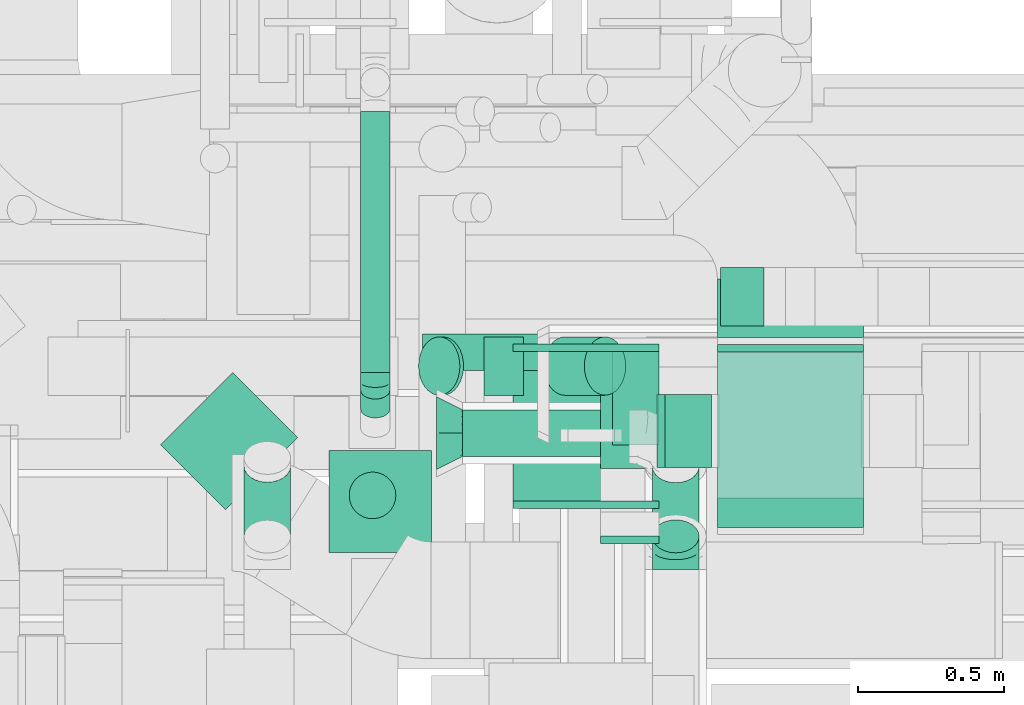
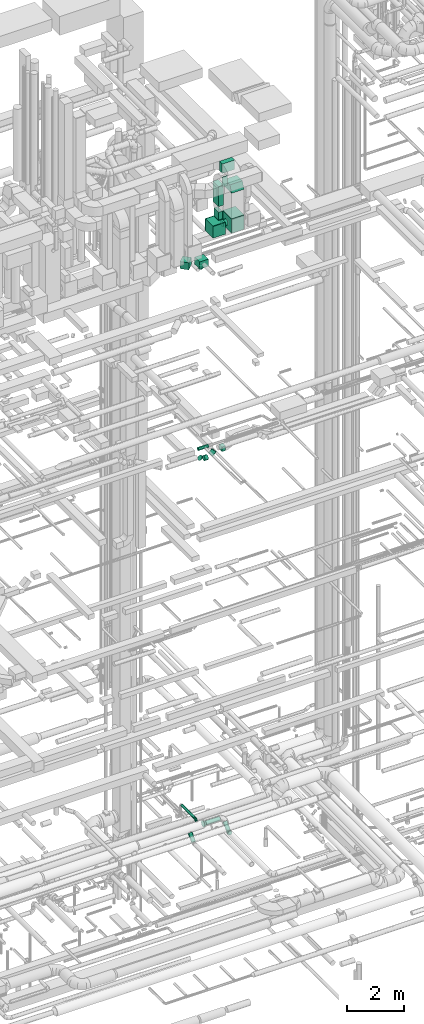
# One storey, part 232 of 337: 19 flow segments, 11 flow fittings.
"""IFC2X3 building model written with IfcOpenShell, lengths in millimetres."""

from ifc_helpers import new_model, entity, si_unit, converted_unit, derived_unit, direction, frame, origin, origin_2d_with_axis, place, context, subcontext, project, spatial, polyline, rectangle, circle, outline, extrude, faceted_brep, source, transform, mapped, material, type_object, type_shapes, element, save


model = new_model("IFC2X3")

# Units and contexts
model_context = context("Model", 3, precision=0.01, world=origin(), true_north=direction((6.12303176911189e-17, 1.0)))
body_context = subcontext(model_context, "Body", "Model", "MODEL_VIEW")
ifc_project = project(units=[si_unit("LENGTHUNIT", "METRE", prefix="MILLI"), si_unit("AREAUNIT", "SQUARE_METRE"), si_unit("VOLUMEUNIT", "CUBIC_METRE"), converted_unit("PLANEANGLEUNIT", "DEGREE", entity("IfcRatioMeasure", 0.0174532925199433), si_unit("PLANEANGLEUNIT", "RADIAN"), dimensions=[0, 0, 0, 0, 0, 0, 0]), si_unit("MASSUNIT", "GRAM", prefix="KILO"), derived_unit("MASSDENSITYUNIT", [(si_unit("MASSUNIT", "GRAM", prefix="KILO"), 1), (si_unit("LENGTHUNIT", "METRE"), -3)]), derived_unit("MOMENTOFINERTIAUNIT", [(si_unit("LENGTHUNIT", "METRE"), 4)]), si_unit("TIMEUNIT", "SECOND"), si_unit("FREQUENCYUNIT", "HERTZ"), si_unit("THERMODYNAMICTEMPERATUREUNIT", "DEGREE_CELSIUS"), derived_unit("THERMALTRANSMITTANCEUNIT", [(si_unit("MASSUNIT", "GRAM", prefix="KILO"), 1), (si_unit("THERMODYNAMICTEMPERATUREUNIT", "KELVIN"), -1), (si_unit("TIMEUNIT", "SECOND"), -3)]), derived_unit("VOLUMETRICFLOWRATEUNIT", [(si_unit("LENGTHUNIT", "METRE"), 3), (si_unit("TIMEUNIT", "SECOND"), -1)]), derived_unit("MASSFLOWRATEUNIT", [(si_unit("MASSUNIT", "GRAM", prefix="KILO"), 1), (si_unit("TIMEUNIT", "SECOND"), -1)]), derived_unit("ROTATIONALFREQUENCYUNIT", [(si_unit("TIMEUNIT", "SECOND"), -1)]), si_unit("ELECTRICCURRENTUNIT", "AMPERE"), si_unit("ELECTRICVOLTAGEUNIT", "VOLT"), si_unit("POWERUNIT", "WATT"), si_unit("FORCEUNIT", "NEWTON", prefix="KILO"), si_unit("ILLUMINANCEUNIT", "LUX"), si_unit("LUMINOUSFLUXUNIT", "LUMEN"), si_unit("LUMINOUSINTENSITYUNIT", "CANDELA"), derived_unit("USERDEFINED", [(si_unit("MASSUNIT", "GRAM", prefix="KILO"), -1), (si_unit("LENGTHUNIT", "METRE"), -2), (si_unit("TIMEUNIT", "SECOND"), 3), (si_unit("LUMINOUSFLUXUNIT", "LUMEN"), 1)]), derived_unit("LINEARVELOCITYUNIT", [(si_unit("LENGTHUNIT", "METRE"), 1), (si_unit("TIMEUNIT", "SECOND"), -1)]), si_unit("PRESSUREUNIT", "PASCAL"), derived_unit("USERDEFINED", [(si_unit("LENGTHUNIT", "METRE"), -2), (si_unit("MASSUNIT", "GRAM", prefix="KILO"), 1), (si_unit("TIMEUNIT", "SECOND"), -2)]), derived_unit("LINEARFORCEUNIT", [(si_unit("MASSUNIT", "GRAM", prefix="KILO"), 1), (si_unit("LENGTHUNIT", "METRE"), 1), (si_unit("TIMEUNIT", "SECOND"), -2), (si_unit("LENGTHUNIT", "METRE"), -1)]), derived_unit("PLANARFORCEUNIT", [(si_unit("MASSUNIT", "GRAM", prefix="KILO"), 1), (si_unit("LENGTHUNIT", "METRE"), 1), (si_unit("TIMEUNIT", "SECOND"), -2), (si_unit("LENGTHUNIT", "METRE"), -2)])], contexts=[model_context])

# Site, building, storey
site_placement = place(None, origin())
site = spatial("IfcSite", under=ifc_project, at=site_placement, CompositionType="ELEMENT")
building_placement = place(site_placement, origin())
building = spatial("IfcBuilding", under=site, at=building_placement, CompositionType="ELEMENT")
storey_placement = place(building_placement, origin())
storey = spatial("IfcBuildingStorey", under=building, at=storey_placement, CompositionType="ELEMENT", Elevation=0.0)

# Flow segments
duct_segment_type_1 = type_object("IfcDuctSegmentType", PredefinedType="NOTDEFINED")
flow_segment_1_placement = place(storey_placement, frame((61880.06, 9475.53, 18750.0)))
element("IfcFlowSegment", 1, at=flow_segment_1_placement, inside=storey, type_object=duct_segment_type_1, context=body_context, shape_type="SweptSolid", body=[
    extrude(rectangle(XDim=148.732589066645, YDim=200.0, at=origin_2d_with_axis()), frame((74.37, 100.0, 0.0)), (0.0, 0.0, 1.0), 199.999999999998),
])
flow_segment_2_placement = place(storey_placement, frame((60539.45, 8700.02, 27450.0)))
element("IfcFlowSegment", 2, at=flow_segment_2_placement, inside=storey, type_object=duct_segment_type_1, context=body_context, shape_type="SweptSolid", body=[
    extrude(rectangle(XDim=352.280592228734, YDim=349.999999999999, at=origin_2d_with_axis()), frame((176.14, 175.0, 0.0), z_axis=(0.0, 0.0, 1.0), x_axis=(-1.0, 0.0, 0.0)), (0.0, 0.0, 1.0), 300.000000000001),
])
flow_segment_3_placement = place(storey_placement, frame((61870.03, 9436.6, 30600.0)))
element("IfcFlowSegment", 3, at=flow_segment_3_placement, inside=storey, type_object=duct_segment_type_1, context=body_context, shape_type="SweptSolid", body=[
    extrude(rectangle(XDim=200.89666130683, YDim=499.999999999999, at=origin_2d_with_axis()), frame((250.0, 100.45, 0.0), z_axis=(0.0, 0.0, 1.0), x_axis=(0.0, 1.0, 0.0)), (0.0, 0.0, 1.0), 400.000000000004),
])
flow_segment_4_placement = place(storey_placement, frame((61870.03, 8786.6, 28450.0)))
element("IfcFlowSegment", 4, at=flow_segment_4_placement, inside=storey, type_object=duct_segment_type_1, context=body_context, shape_type="SweptSolid", body=[
    extrude(rectangle(XDim=600.0, YDim=499.999999999999, at=origin_2d_with_axis()), frame((250.0, 300.0, 0.0), z_axis=(0.0, 0.0, 1.0), x_axis=(0.0, 1.0, 0.0)), (0.0, 0.0, 1.0), 600.000000000002),
])
flow_segment_5_placement = place(storey_placement, frame((61170.03, 8876.6, 28450.0)))
element("IfcFlowSegment", 5, at=flow_segment_5_placement, inside=storey, type_object=duct_segment_type_1, context=body_context, shape_type="SweptSolid", body=[
    extrude(rectangle(XDim=512.000000000001, YDim=499.999999999999, at=origin_2d_with_axis()), frame((250.0, 256.0, 0.0), z_axis=(0.0, 0.0, 1.0), x_axis=(0.0, 1.0, 0.0)), (0.0, 0.0, 1.0), 499.999999999999),
])
flow_segment_6_placement = place(storey_placement, frame((61510.03, 9068.6, 28970.0)))
element("IfcFlowSegment", 6, at=flow_segment_6_placement, inside=storey, type_object=duct_segment_type_1, context=body_context, shape_type="SweptSolid", body=[
    extrude(rectangle(XDim=159.999999999998, YDim=320.0, at=origin_2d_with_axis()), frame((80.0, 160.0, 0.0), z_axis=(0.0, 0.0, 1.0), x_axis=(-1.0, 0.0, 0.0)), (0.0, 0.0, 1.0), 330.000000000055),
])
flow_segment_7_placement = place(storey_placement, frame((61470.03, 8988.6, 29600.0)))
element("IfcFlowSegment", 7, at=flow_segment_7_placement, inside=storey, type_object=duct_segment_type_1, context=body_context, shape_type="SweptSolid", body=[
    extrude(rectangle(XDim=399.999999999999, YDim=199.999999999998, at=origin_2d_with_axis()), frame((100.0, 200.0, 0.0), z_axis=(0.0, 0.0, 1.0), x_axis=(0.0, -1.0, 0.0)), (0.0, 0.0, 1.0), 850.000025000003),
])
flow_segment_8_placement = place(storey_placement, frame((59963.18, 8846.47, 27450.0)))
element("IfcFlowSegment", 8, at=flow_segment_8_placement, inside=storey, type_object=duct_segment_type_1, context=body_context, shape_type="SweptSolid", body=[
    extrude(rectangle(XDim=314.97280707382, YDim=349.999999999997, at=origin_2d_with_axis()), frame((235.1, 235.1, 0.0), z_axis=(0.0, 0.0, 1.0), x_axis=(-0.707106781186537, 0.707106781186558, 0.0)), (0.0, 0.0, 1.0), 300.000000000001),
])
duct_segment_type_2 = type_object("IfcDuctSegmentType", PredefinedType="NOTDEFINED")
flow_segment_9_placement = place(storey_placement, frame((60997.4, 9027.05, 3418.43)))
element("IfcFlowSegment", 9, at=flow_segment_9_placement, inside=storey, type_object=duct_segment_type_2, context=body_context, shape_type="SweptSolid", body=[
    extrude(circle(Radius=80.0, at=origin_2d_with_axis()), frame((0.0, 81.6, 81.6), z_axis=(1.0, 0.0, 0.0), x_axis=(0.0, 1.0, 0.0)), (0.0, 0.0, 1.0), 570.000194736215),
])
flow_segment_10_placement = place(storey_placement, frame((60859.84, 9321.02, 19210.9)))
element("IfcFlowSegment", 10, at=flow_segment_10_placement, inside=storey, type_object=duct_segment_type_2, context=body_context, shape_type="SweptSolid", body=[
    extrude(circle(Radius=62.5, at=origin_2d_with_axis()), frame((0.0, 64.1, 64.1), z_axis=(1.0, 0.0, 0.0), x_axis=(0.0, 1.0, 0.0)), (0.0, 0.0, 1.0), 410.000000000115),
])
flow_segment_11_placement = place(storey_placement, frame((61071.51, 9236.98, 18743.4)))
element("IfcFlowSegment", 11, at=flow_segment_11_placement, inside=storey, type_object=duct_segment_type_2, context=body_context, shape_type="SweptSolid", body=[
    extrude(circle(Radius=100.0, at=origin_2d_with_axis()), frame((0.0, 101.6, 101.6), z_axis=(1.0, 0.0, 0.0), x_axis=(0.0, -1.0, 0.0)), (0.0, 0.0, 1.0), 134.314575050791),
])
flow_segment_12_placement = place(storey_placement, frame((60845.12, 9236.98, 18831.27)))
element("IfcFlowSegment", 12, at=flow_segment_12_placement, inside=storey, type_object=duct_segment_type_2, context=body_context, shape_type="SweptSolid", body=[
    extrude(circle(Radius=100.0, at=origin_2d_with_axis()), frame((84.96, 101.6, 72.31), z_axis=(-0.707106781186417, 0.0, 0.707106781186678), x_axis=(0.0, 1.0, 0.0)), (0.0, 0.0, 1.0), 17.9011977120001),
])
flow_segment_13_placement = place(storey_placement, frame((61274.94, 9236.98, 18831.27)))
element("IfcFlowSegment", 13, at=flow_segment_13_placement, inside=storey, type_object=duct_segment_type_2, context=body_context, shape_type="SweptSolid", body=[
    extrude(circle(Radius=100.0, at=origin_2d_with_axis()), frame((72.31, 101.6, 72.31), z_axis=(0.707106781186552, 0.0, 0.707106781186543), x_axis=(0.0, -1.0, 0.0)), (0.0, 0.0, 1.0), 194.93903345586),
])
flow_segment_14_placement = place(storey_placement, frame((61690.03, 8988.89, 28613.4)))
element("IfcFlowSegment", 14, at=flow_segment_14_placement, inside=storey, type_object=duct_segment_type_2, context=body_context, shape_type="SweptSolid", body=[
    extrude(circle(Radius=125.0, at=origin_2d_with_axis()), frame((0.0, 126.6, 126.6), z_axis=(1.0, 0.0, 0.0), x_axis=(0.0, -1.0, 0.0)), (0.0, 0.0, 1.0), 159.999999999929),
])
flow_segment_15_placement = place(storey_placement, frame((60247.19, 8696.29, 3088.7)))
element("IfcFlowSegment", 15, at=flow_segment_15_placement, inside=storey, type_object=duct_segment_type_2, context=body_context, shape_type="SweptSolid", body=[
    extrude(circle(Radius=80.0, at=origin_2d_with_axis()), frame((81.6, 58.17, 58.16), z_axis=(0.0, 0.707065975990968, 0.707147584027507), x_axis=(-1.0, 0.0, 0.0)), (0.0, 0.0, 1.0), 343.340340356548),
])
flow_segment_16_placement = place(storey_placement, frame((60646.81, 9315.73, 3648.4)))
element("IfcFlowSegment", 16, at=flow_segment_16_placement, inside=storey, type_object=duct_segment_type_2, context=body_context, shape_type="SweptSolid", body=[
    extrude(circle(Radius=50.0, at=origin_2d_with_axis()), frame((51.6, 0.0, 51.6), z_axis=(0.0, 1.0, 0.0), x_axis=(-1.0, 0.0, 0.0)), (0.0, 0.0, 1.0), 894.354512811127),
])
flow_segment_17_placement = place(storey_placement, frame((60607.25, 8814.03, 27320.0)))
element("IfcFlowSegment", 17, at=flow_segment_17_placement, inside=storey, type_object=duct_segment_type_2, context=body_context, shape_type="SweptSolid", body=[
    extrude(circle(Radius=80.0, at=origin_2d_with_axis()), frame((81.6, 81.6, 0.0)), (0.0, 0.0, 1.0), 109.999999999901),
])
flow_segment_18_placement = place(storey_placement, frame((61645.81, 8697.35, 3088.7)))
element("IfcFlowSegment", 18, at=flow_segment_18_placement, inside=storey, type_object=duct_segment_type_2, context=body_context, shape_type="SweptSolid", body=[
    extrude(circle(Radius=80.0, at=origin_2d_with_axis()), frame((81.6, 58.17, 58.16), z_axis=(0.0, 0.707057032292688, 0.707156526580542), x_axis=(1.0, 0.0, 0.0)), (0.0, 0.0, 1.0), 339.426965556956),
])
flow_segment_19_placement = place(storey_placement, frame((60646.81, 9159.44, 3589.8)))
element("IfcFlowSegment", 19, at=flow_segment_19_placement, inside=storey, type_object=duct_segment_type_2, context=body_context, shape_type="SweptSolid", body=[
    extrude(circle(Radius=50.0, at=origin_2d_with_axis()), frame((51.6, 31.67, 41.54), z_axis=(0.0, 0.798836695069903, 0.601547948720461), x_axis=(1.0, 0.0, 0.0)), (0.0, 0.0, 1.0), 80.6610962379535),
])

# Flow fittings
ifc_material = material()
duct_fitting_type_1 = type_object("IfcDuctFittingType", PredefinedType="NOTDEFINED", material=ifc_material)
shared_shape_1 = source(origin(), body_context, "Body", "SweptSolid", [
    extrude(rectangle(XDim=200.0, YDim=26.096, at=origin_2d_with_axis()), frame((6.95, 0.0, -200.0), z_axis=(0.0, 0.0, 1.0), x_axis=(0.0, -1.0, 0.0)), (0.0, 0.0, 1.0), 400.0),
])
type_shapes(duct_fitting_type_1, [shared_shape_1])
flow_fitting_1_placement = place(storey_placement, frame((61570.03, 8736.6, 30800.0), z_axis=(0.0, 0.0, -1.0), x_axis=(0.0, 1.0, 0.0)))
element("IfcFlowFitting", 20, at=flow_fitting_1_placement, inside=storey, type_object=duct_fitting_type_1, material=ifc_material, context=body_context, shape_type="MappedRepresentation", body=[
    mapped(shared_shape_1, transform((0.0, 0.0, 0.0), scale=1.0)),
])
duct_fitting_type_2 = type_object("IfcDuctFittingType", PredefinedType="NOTDEFINED", material=ifc_material)
shared_shape_2 = source(origin(), body_context, "Body", "SweptSolid", [
    extrude(rectangle(XDim=24.9999999999999, YDim=500.0, at=origin_2d_with_axis()), frame((12.5, 0.0, -300.0)), (0.0, 0.0, 1.0), 600.0),
])
type_shapes(duct_fitting_type_2, [shared_shape_2])
flow_fitting_2_placement = place(storey_placement, frame((62120.03, 9386.6, 28750.0), z_axis=(0.0, 0.0, 1.0), x_axis=(0.0, 1.0, 0.0)))
element("IfcFlowFitting", 21, at=flow_fitting_2_placement, inside=storey, type_object=duct_fitting_type_2, material=ifc_material, context=body_context, shape_type="MappedRepresentation", body=[
    mapped(shared_shape_2, transform((0.0, 0.0, 0.0), scale=1.0)),
])
duct_fitting_type_3 = type_object("IfcDuctFittingType", PredefinedType="NOTDEFINED", material=ifc_material)
shared_shape_3 = source(origin(), body_context, "Body", "SweptSolid", [
    extrude(outline(polyline([(-237.17, -237.17), (79.06, -237.17), (205.55, 142.3), (-47.43, 332.04), (-237.17, -237.17)])), frame((150.0, -250.0, 0.0), z_axis=(0.0, 1.0, 0.0), x_axis=(0.948683298050486, 0.0, -0.316227766016921)), (0.0, 0.0, 1.0), 500.0),
])
type_shapes(duct_fitting_type_3, [shared_shape_3])
flow_fitting_3_placement = place(storey_placement, frame((62120.03, 9086.6, 30150.0), z_axis=(0.0, -1.0, 0.0), x_axis=(0.0, 0.0, 1.0)))
element("IfcFlowFitting", 22, at=flow_fitting_3_placement, inside=storey, type_object=duct_fitting_type_3, material=ifc_material, context=body_context, shape_type="MappedRepresentation", body=[
    mapped(shared_shape_3, transform((0.0, 0.0, 0.0), scale=1.0)),
])
duct_fitting_type_4 = type_object("IfcDuctFittingType", PredefinedType="NOTDEFINED", material=ifc_material)
shared_shape_4 = source(origin(), body_context, "Body", "SweptSolid", [
    extrude(rectangle(XDim=500.0, YDim=26.096, at=origin_2d_with_axis()), frame((6.95, 0.0, -300.0), z_axis=(0.0, 0.0, 1.0), x_axis=(0.0, -1.0, 0.0)), (0.0, 0.0, 1.0), 600.0),
])
type_shapes(duct_fitting_type_4, [shared_shape_4])
flow_fitting_4_placement = place(storey_placement, frame((62120.03, 9086.6, 29050.0), z_axis=(0.0, -1.0, 0.0), x_axis=(0.0, 0.0, 1.0)))
element("IfcFlowFitting", 23, at=flow_fitting_4_placement, inside=storey, type_object=duct_fitting_type_4, material=ifc_material, context=body_context, shape_type="MappedRepresentation", body=[
    mapped(shared_shape_4, transform((0.0, 0.0, 0.0), scale=1.0)),
])
duct_fitting_type_5 = type_object("IfcDuctFittingType", PredefinedType="NOTDEFINED", material=ifc_material)
shared_shape_5 = source(origin(), body_context, "Body", "SweptSolid", [
    extrude(rectangle(XDim=160.0, YDim=26.096, at=origin_2d_with_axis()), frame((6.95, 0.0, -160.0), z_axis=(0.0, 0.0, 1.0), x_axis=(0.0, -1.0, 0.0)), (0.0, 0.0, 1.0), 320.0),
])
type_shapes(duct_fitting_type_5, [shared_shape_5])
flow_fitting_5_placement = place(storey_placement, frame((61590.03, 9228.6, 28950.0), z_axis=(0.0, -1.0, 0.0), x_axis=(0.0, 0.0, 1.0)))
element("IfcFlowFitting", 24, at=flow_fitting_5_placement, inside=storey, type_object=duct_fitting_type_5, material=ifc_material, context=body_context, shape_type="MappedRepresentation", body=[
    mapped(shared_shape_5, transform((0.0, 0.0, 0.0), scale=1.0)),
])
duct_fitting_type_6 = type_object("IfcDuctFittingType", PredefinedType="NOTDEFINED", material=ifc_material)
shared_shape_6 = source(origin(), body_context, "Body", "SweptSolid", [
    extrude(rectangle(XDim=24.9999999999999, YDim=500.0, at=origin_2d_with_axis()), frame((12.5, 0.0, -250.0)), (0.0, 0.0, 1.0), 500.0),
])
type_shapes(duct_fitting_type_6, [shared_shape_6])
for number, where, z_axis, x_axis in (
    (25, (61420.03, 8876.6, 28700.0), (0.0, 0.0, 1.0), (0.0, -1.0, 0.0)),
    (26, (61420.03, 9388.6, 28700.0), (0.0, 0.0, 1.0), (0.0, 1.0, 0.0)),
):
    element("IfcFlowFitting", number, at=place(storey_placement, frame(where, z_axis=z_axis, x_axis=x_axis)), inside=storey, type_object=duct_fitting_type_6, material=ifc_material, context=body_context, shape_type="MappedRepresentation", body=[
        mapped(shared_shape_6, transform((0.0, 0.0, 0.0), scale=1.0)),
    ])
duct_fitting_type_7 = type_object("IfcDuctFittingType", PredefinedType="NOTDEFINED", material=ifc_material)
shared_shape_7 = source(origin(), body_context, "Body", "Brep", [
    faceted_brep([(20.0, 32.35, -120.74), (20.0, 62.5, -108.25), (20.0, 88.39, -88.39), (20.0, 108.25, -62.5), (20.0, 120.74, -32.35), (20.0, 125.0, 0.0), (20.0, 120.74, 32.35), (20.0, 108.25, 62.5), (20.0, 88.39, 88.39), (20.0, 62.5, 108.25), (20.0, 32.35, 120.74), (20.0, 0.0, 125.0), (20.0, -32.35, 120.74), (20.0, -62.5, 108.25), (20.0, -88.39, 88.39), (20.0, -108.25, 62.5), (20.0, -120.74, 32.35), (20.0, -125.0, 0.0), (20.0, -120.74, -32.35), (20.0, -108.25, -62.5), (20.0, -88.39, -88.39), (20.0, -62.5, -108.25), (20.0, -32.35, -120.74), (20.0, 0.0, -125.0), (0.0, 0.0, 125.0), (0.0, 32.35, 120.74), (-6.1, 32.35, 120.74), (-6.1, 0.0, 125.0), (0.0, 62.5, 108.25), (-6.1, 62.5, 108.25), (0.0, 88.39, 88.39), (-6.1, 88.39, 88.39), (0.0, 108.25, 62.5), (0.0, 120.74, 32.35), (-6.1, 120.74, 32.35), (-6.1, 108.25, 62.5), (0.0, 125.0, 0.0), (-6.1, 125.0, 0.0), (0.0, 120.74, -32.35), (-6.1, 120.74, -32.35), (0.0, 108.25, -62.5), (-6.1, 108.25, -62.5), (0.0, 88.39, -88.39), (-6.1, 88.39, -88.39), (0.0, 62.5, -108.25), (0.0, 32.35, -120.74), (-6.1, 32.35, -120.74), (-6.1, 62.5, -108.25), (0.0, 0.0, -125.0), (-6.1, 0.0, -125.0), (0.0, -32.35, -120.74), (-6.1, -32.35, -120.74), (0.0, -62.5, -108.25), (-6.1, -62.5, -108.25), (0.0, -88.39, -88.39), (-6.1, -88.39, -88.39), (0.0, -108.25, -62.5), (0.0, -120.74, -32.35), (-6.1, -120.74, -32.35), (-6.1, -108.25, -62.5), (0.0, -125.0, 0.0), (-6.1, -125.0, 0.0), (0.0, -120.74, 32.35), (-6.1, -120.74, 32.35), (0.0, -108.25, 62.5), (-6.1, -108.25, 62.5), (0.0, -88.39, 88.39), (-6.1, -88.39, 88.39), (0.0, -62.5, 108.25), (0.0, -32.35, 120.74), (-6.1, -32.35, 120.74), (-6.1, -62.5, 108.25)], [[[0, 1, 2, 3, 4, 5, 6, 7, 8, 9, 10, 11, 12, 13, 14, 15, 16, 17, 18, 19, 20, 21, 22, 23]], [[24, 11, 10, 25, 26, 27]], [[25, 10, 9, 28, 29, 26]], [[28, 9, 8, 30, 31, 29]], [[32, 7, 6, 33, 34, 35]], [[33, 6, 5, 36, 37, 34]], [[30, 8, 7, 32, 35, 31]], [[36, 5, 4, 38, 39, 37]], [[38, 4, 3, 40, 41, 39]], [[40, 3, 2, 42, 43, 41]], [[44, 1, 0, 45, 46, 47]], [[45, 0, 23, 48, 49, 46]], [[42, 2, 1, 44, 47, 43]], [[48, 23, 22, 50, 51, 49]], [[50, 22, 21, 52, 53, 51]], [[52, 21, 20, 54, 55, 53]], [[56, 19, 18, 57, 58, 59]], [[57, 18, 17, 60, 61, 58]], [[54, 20, 19, 56, 59, 55]], [[60, 17, 16, 62, 63, 61]], [[62, 16, 15, 64, 65, 63]], [[64, 15, 14, 66, 67, 65]], [[68, 13, 12, 69, 70, 71]], [[69, 12, 11, 24, 27, 70]], [[66, 14, 13, 68, 71, 67]], [[49, 51, 53, 55, 59, 58, 61, 63, 65, 67, 71, 70, 27, 26, 29, 31, 35, 34, 37, 39, 41, 43, 47, 46]]]),
])
type_shapes(duct_fitting_type_7, [shared_shape_7])
flow_fitting_6_placement = place(storey_placement, frame((61670.03, 9115.48, 28740.0), z_axis=(0.0, 0.0, -1.0), x_axis=(1.0, 0.0, 0.0)))
element("IfcFlowFitting", 27, at=flow_fitting_6_placement, inside=storey, type_object=duct_fitting_type_7, material=ifc_material, context=body_context, shape_type="MappedRepresentation", body=[
    mapped(shared_shape_7, transform((0.0, 0.0, 0.0), scale=1.0)),
])
duct_fitting_type_8 = type_object("IfcDuctFittingType", PredefinedType="NOTDEFINED", material=ifc_material)
shared_shape_8 = source(origin(), body_context, "Body", "Brep", [
    faceted_brep([(-66.27, 0.0, -80.0), (-66.27, -20.71, -77.27), (-66.27, -40.0, -69.28), (-66.27, -56.57, -56.57), (-66.27, -69.28, -40.0), (-66.27, -77.27, -20.71), (-66.27, -80.0, 0.0), (-66.27, -77.27, 20.71), (-66.27, -69.28, 40.0), (-66.27, -56.57, 56.57), (-66.27, -40.0, 69.28), (-66.27, -20.71, 77.27), (-66.27, 0.0, 80.0), (-66.27, 20.71, 77.27), (-66.27, 40.0, 69.28), (-66.27, 56.57, 56.57), (-66.27, 69.28, 40.0), (-66.27, 77.27, 20.71), (-66.27, 80.0, 0.0), (-66.27, 77.27, -20.71), (-66.27, 69.28, -40.0), (-66.27, 56.57, -56.57), (-66.27, 40.0, -69.28), (-66.27, 20.71, -77.27), (-8.58, 20.71, 77.27), (-16.57, 40.0, 69.28), (0.0, 0.0, 80.0), (-23.43, 56.57, 56.57), (-28.7, 69.28, 40.0), (-32.01, 77.27, 20.71), (-33.14, 80.0, 0.0), (-32.01, 77.27, -20.71), (-28.7, 69.28, -40.0), (-23.43, 56.57, -56.57), (-8.58, 20.71, -77.27), (0.0, 0.0, -80.0), (-16.57, 40.0, -69.28), (8.58, -20.71, -77.27), (16.57, -40.0, -69.28), (23.43, -56.57, -56.57), (28.7, -69.28, -40.0), (32.01, -77.27, -20.71), (33.14, -80.0, 0.0), (32.01, -77.27, 20.71), (28.7, -69.28, 40.0), (23.43, -56.57, 56.57), (16.57, -40.0, 69.28), (8.58, -20.71, 77.27), (46.86, 46.86, 80.0), (32.22, 61.5, 77.27), (18.58, 75.15, 69.28), (6.86, 86.86, 56.57), (-2.13, 95.85, 40.0), (-7.78, 101.5, 20.71), (-9.71, 103.43, 0.0), (-7.78, 101.5, -20.71), (-2.13, 95.85, -40.0), (6.86, 86.86, -56.57), (18.58, 75.15, -69.28), (32.22, 61.5, -77.27), (46.86, 46.86, -80.0), (61.5, 32.22, -77.27), (75.15, 18.58, -69.28), (86.86, 6.86, -56.57), (95.85, -2.13, -40.0), (101.5, -7.78, -20.71), (103.43, -9.71, 0.0), (101.5, -7.78, 20.71), (95.85, -2.13, 40.0), (86.86, 6.86, 56.57), (75.15, 18.58, 69.28), (61.5, 32.22, 77.27)], [[[0, 1, 2, 3, 4, 5, 6, 7, 8, 9, 10, 11, 12, 13, 14, 15, 16, 17, 18, 19, 20, 21, 22, 23]], [[24, 25, 14, 13]], [[26, 24, 13, 12]], [[14, 25, 27, 15]], [[28, 29, 17, 16]], [[28, 16, 15, 27]], [[30, 18, 17, 29]], [[31, 32, 20, 19]], [[30, 31, 19, 18]], [[32, 33, 21, 20]], [[34, 35, 0, 23]], [[36, 34, 23, 22]], [[33, 36, 22, 21]], [[1, 0, 35, 37]], [[2, 1, 37, 38]], [[38, 39, 3, 2]], [[5, 4, 40, 41]], [[6, 5, 41, 42]], [[39, 40, 4, 3]], [[6, 42, 43, 7]], [[7, 43, 44, 8]], [[8, 44, 45, 9]], [[9, 45, 46, 10]], [[10, 46, 47, 11]], [[26, 12, 11, 47]], [[24, 26, 48, 49]], [[25, 24, 49, 50]], [[27, 25, 50, 51]], [[29, 28, 52, 53]], [[30, 29, 53, 54]], [[51, 52, 28, 27]], [[30, 54, 55, 31]], [[31, 55, 56, 32]], [[57, 33, 32, 56]], [[36, 58, 59, 34]], [[34, 59, 60, 35]], [[58, 36, 33, 57]], [[35, 60, 61, 37]], [[37, 61, 62, 38]], [[63, 39, 38, 62]], [[40, 64, 65, 41]], [[41, 65, 66, 42]], [[64, 40, 39, 63]], [[43, 42, 66, 67]], [[44, 43, 67, 68]], [[68, 69, 45, 44]], [[47, 46, 70, 71]], [[26, 47, 71, 48]], [[69, 70, 46, 45]], [[59, 58, 57, 56, 55, 54, 53, 52, 51, 50, 49, 48, 71, 70, 69, 68, 67, 66, 65, 64, 63, 62, 61, 60]]]),
])
type_shapes(duct_fitting_type_8, [shared_shape_8])
flow_fitting_7_placement = place(storey_placement, frame((61727.4, 8708.65, 3100.0), z_axis=(1.0, 0.0, 0.0), x_axis=(0.0, 1.0, 0.0)))
element("IfcFlowFitting", 28, at=flow_fitting_7_placement, inside=storey, type_object=duct_fitting_type_8, material=ifc_material, context=body_context, shape_type="MappedRepresentation", body=[
    mapped(shared_shape_8, transform((0.0, 0.0, 0.0), scale=1.0)),
])
duct_fitting_type_9 = type_object("IfcDuctFittingType", PredefinedType="NOTDEFINED", material=ifc_material)
shared_shape_9 = source(origin(), body_context, "Body", "Brep", [
    faceted_brep([(-33.46, 0.0, -50.0), (-33.46, -12.94, -48.3), (-33.46, -25.0, -43.3), (-33.46, -35.36, -35.36), (-33.46, -43.3, -25.0), (-33.46, -48.3, -12.94), (-33.46, -50.0, 0.0), (-33.46, -48.3, 12.94), (-33.46, -43.3, 25.0), (-33.46, -35.36, 35.36), (-33.46, -25.0, 43.3), (-33.46, -12.94, 48.3), (-33.46, 0.0, 50.0), (-33.46, 12.94, 48.3), (-33.46, 25.0, 43.3), (-33.46, 35.36, 35.36), (-33.46, 43.3, 25.0), (-33.46, 48.3, 12.94), (-33.46, 50.0, 0.0), (-33.46, 48.3, -12.94), (-33.46, 43.3, -25.0), (-33.46, 35.36, -35.36), (-33.46, 25.0, -43.3), (-33.46, 12.94, -48.3), (-4.33, 12.94, 48.3), (-8.36, 25.0, 43.3), (0.0, 0.0, 50.0), (-11.83, 35.36, 35.36), (-16.16, 48.3, 12.94), (-16.73, 50.0, 0.0), (-14.49, 43.3, 25.0), (-14.49, 43.3, -25.0), (-11.83, 35.36, -35.36), (-16.16, 48.3, -12.94), (-4.33, 12.94, -48.3), (0.0, 0.0, -50.0), (-8.36, 25.0, -43.3), (4.33, -12.94, -48.3), (8.36, -25.0, -43.3), (11.83, -35.36, -35.36), (14.49, -43.3, -25.0), (16.16, -48.3, -12.94), (16.73, -50.0, 0.0), (16.16, -48.3, 12.94), (14.49, -43.3, 25.0), (11.83, -35.36, 35.36), (8.36, -25.0, 43.3), (4.33, -12.94, 48.3), (26.72, 20.14, 50.0), (18.93, 30.47, 48.3), (11.68, 40.1, 43.3), (5.44, 48.37, 35.36), (0.66, 54.72, 25.0), (-2.34, 58.71, 12.94), (-3.37, 60.07, 0.0), (-2.34, 58.71, -12.94), (0.66, 54.72, -25.0), (5.44, 48.37, -35.36), (11.68, 40.1, -43.3), (18.93, 30.47, -48.3), (26.72, 20.14, -50.0), (34.51, 9.8, -48.3), (41.77, 0.17, -43.3), (48.0, -8.1, -35.36), (52.78, -14.45, -25.0), (55.79, -18.43, -12.94), (56.81, -19.8, 0.0), (55.79, -18.43, 12.94), (52.78, -14.45, 25.0), (48.0, -8.1, 35.36), (41.77, 0.17, 43.3), (34.51, 9.8, 48.3)], [[[0, 1, 2, 3, 4, 5, 6, 7, 8, 9, 10, 11, 12, 13, 14, 15, 16, 17, 18, 19, 20, 21, 22, 23]], [[24, 25, 14, 13]], [[26, 24, 13, 12]], [[14, 25, 27, 15]], [[28, 29, 18, 17]], [[30, 28, 17, 16]], [[15, 27, 30, 16]], [[20, 31, 32, 21]], [[33, 31, 20, 19]], [[18, 29, 33, 19]], [[34, 35, 0, 23]], [[36, 34, 23, 22]], [[21, 32, 36, 22]], [[1, 0, 35, 37]], [[2, 1, 37, 38]], [[3, 2, 38, 39]], [[5, 4, 40, 41]], [[6, 5, 41, 42]], [[39, 40, 4, 3]], [[6, 42, 43, 7]], [[7, 43, 44, 8]], [[8, 44, 45, 9]], [[9, 45, 46, 10]], [[10, 46, 47, 11]], [[26, 12, 11, 47]], [[24, 26, 48, 49]], [[25, 24, 49, 50]], [[27, 25, 50, 51]], [[28, 30, 52, 53]], [[29, 28, 53, 54]], [[27, 51, 52, 30]], [[29, 54, 55, 33]], [[33, 55, 56, 31]], [[31, 56, 57, 32]], [[36, 58, 59, 34]], [[34, 59, 60, 35]], [[36, 32, 57, 58]], [[61, 62, 38, 37]], [[60, 61, 37, 35]], [[63, 39, 38, 62]], [[40, 64, 65, 41]], [[41, 65, 66, 42]], [[64, 40, 39, 63]], [[67, 68, 44, 43]], [[66, 67, 43, 42]], [[68, 69, 45, 44]], [[47, 46, 70, 71]], [[26, 47, 71, 48]], [[69, 70, 46, 45]], [[59, 58, 57, 56, 55, 54, 53, 52, 51, 50, 49, 48, 71, 70, 69, 68, 67, 66, 65, 64, 63, 62, 61, 60]]]),
])
type_shapes(duct_fitting_type_9, [shared_shape_9])
flow_fitting_8_placement = place(storey_placement, frame((60698.4, 9282.27, 3700.0), z_axis=(-1.0, 0.0, 0.0), x_axis=(0.0, 0.798635510047244, 0.601815023152114)))
element("IfcFlowFitting", 29, at=flow_fitting_8_placement, inside=storey, type_object=duct_fitting_type_9, material=ifc_material, context=body_context, shape_type="MappedRepresentation", body=[
    mapped(shared_shape_9, transform((0.0, 0.0, 0.0), scale=1.0)),
])
duct_fitting_type_10 = type_object("IfcDuctFittingType", PredefinedType="NOTDEFINED", material=ifc_material)
shared_shape_10 = source(origin(), body_context, "Body", "Brep", [
    faceted_brep([(90.0, -73.47, -101.13), (90.0, -38.63, -118.88), (90.0, 0.0, -125.0), (90.0, 38.63, -118.88), (90.0, 73.47, -101.13), (90.0, 101.13, -73.47), (90.0, 118.88, -38.63), (90.0, 125.0, 0.0), (90.0, 118.88, 38.63), (90.0, 101.13, 73.47), (90.0, 73.47, 101.13), (90.0, 38.63, 118.88), (90.0, 0.0, 125.0), (90.0, -38.63, 118.88), (90.0, -73.47, 101.13), (90.0, -101.13, 73.47), (90.0, -118.88, 38.63), (90.0, -125.0, 0.0), (90.0, -118.88, -38.63), (90.0, -101.13, -73.47), (0.0, -30.61, -73.91), (0.0, -43.59, -65.24), (0.0, -56.57, -56.57), (0.0, -65.24, -43.59), (0.0, -73.91, -30.61), (0.0, -76.96, -15.31), (0.0, -80.0, 0.0), (0.0, -76.96, 15.31), (0.0, -73.91, 30.61), (0.0, -65.24, 43.59), (0.0, -56.57, 56.57), (0.0, -43.59, 65.24), (0.0, -30.61, 73.91), (0.0, -15.31, 76.96), (0.0, 0.0, 80.0), (0.0, 15.31, 76.96), (0.0, 30.61, 73.91), (0.0, 43.59, 65.24), (0.0, 56.57, 56.57), (0.0, 65.24, 43.59), (0.0, 73.91, 30.61), (0.0, 76.96, 15.31), (0.0, 80.0, 0.0), (0.0, 76.96, -15.31), (0.0, 73.91, -30.61), (0.0, 65.24, -43.59), (0.0, 56.57, -56.57), (0.0, 43.59, -65.24), (0.0, 30.61, -73.91), (0.0, 15.31, -76.96), (0.0, 0.0, -80.0), (0.0, -15.31, -76.96)], [[[0, 1, 2, 3, 4, 5, 6, 7, 8, 9, 10, 11, 12, 13, 14, 15, 16, 17, 18, 19]], [[20, 21, 22, 23, 24, 25, 26, 27, 28, 29, 30, 31, 32, 33, 34, 35, 36, 37, 38, 39, 40, 41, 42, 43, 44, 45, 46, 47, 48, 49, 50, 51]], [[7, 41, 8]], [[41, 40, 8]], [[40, 9, 8]], [[11, 36, 35]], [[41, 7, 42]], [[9, 40, 39, 38]], [[10, 38, 37, 36]], [[12, 35, 34]], [[11, 10, 36]], [[12, 11, 35]], [[38, 10, 9]], [[12, 33, 13]], [[33, 32, 13]], [[32, 14, 13]], [[16, 28, 27]], [[33, 12, 34]], [[14, 32, 31, 30]], [[15, 30, 29, 28]], [[17, 27, 26]], [[16, 15, 28]], [[17, 16, 27]], [[30, 15, 14]], [[17, 25, 18]], [[25, 24, 18]], [[24, 19, 18]], [[1, 20, 51]], [[25, 17, 26]], [[19, 24, 23, 22]], [[0, 22, 21, 20]], [[2, 51, 50]], [[1, 0, 20]], [[2, 1, 51]], [[22, 0, 19]], [[2, 49, 3]], [[49, 48, 3]], [[48, 4, 3]], [[6, 44, 43]], [[49, 2, 50]], [[4, 48, 47, 46]], [[5, 46, 45, 44]], [[7, 43, 42]], [[6, 5, 44]], [[7, 6, 43]], [[46, 5, 4]]]),
])
type_shapes(duct_fitting_type_10, [shared_shape_10])
flow_fitting_9_placement = place(storey_placement, frame((60997.4, 9108.65, 3500.03), z_axis=(1.7235915570503e-06, 0.0, 1.0), x_axis=(-1.0, 0.0, 1.7235915570503e-06)))
element("IfcFlowFitting", 30, at=flow_fitting_9_placement, inside=storey, type_object=duct_fitting_type_10, material=ifc_material, context=body_context, shape_type="MappedRepresentation", body=[
    mapped(shared_shape_10, transform((0.0, 0.0, 0.0), scale=1.0)),
])

save(model, "model.ifc")
